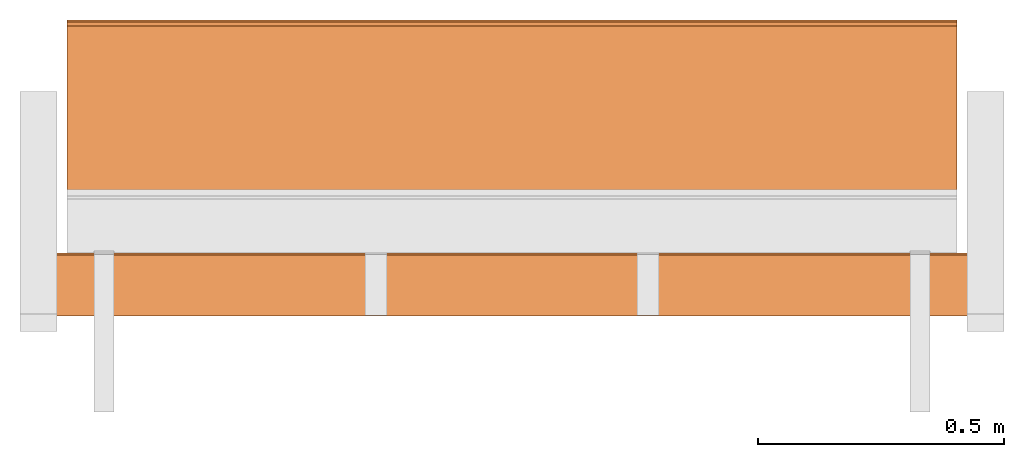
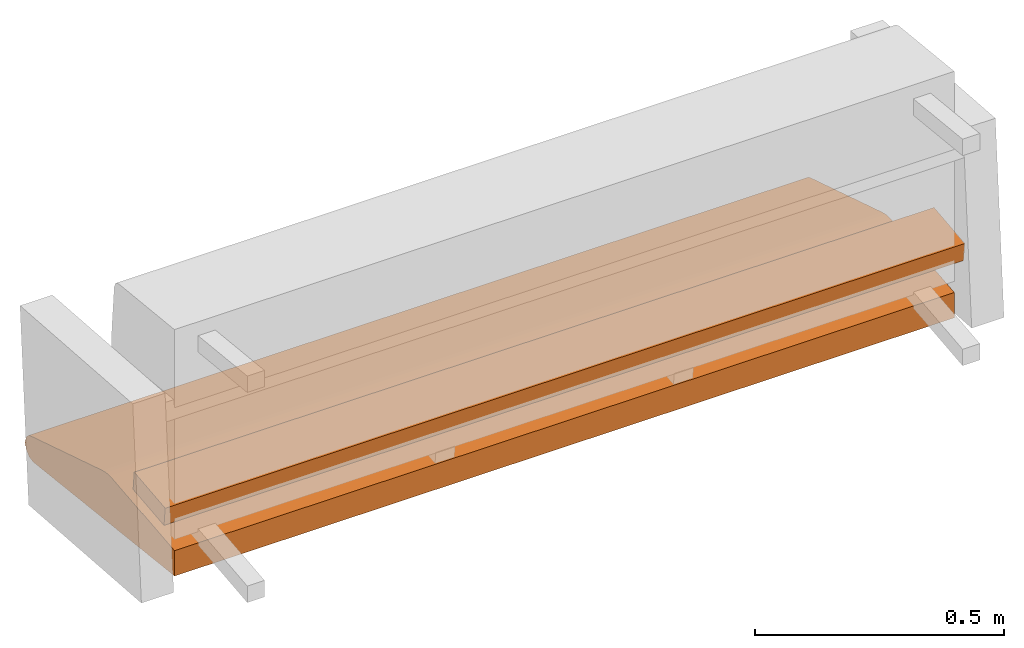
# One storey, part 2 of 4: 2 proxies, 1 element without a shape of its own.
"""IFC2X3 building model written with IfcOpenShell, lengths in metres."""

from ifc_helpers import new_model, si_unit, direction, origin_with_axes, place, context, project, spatial, faceted_brep, source, transform, mapped, element, aggregate, save


model = new_model("IFC2X3")

# Units and contexts
model_context = context("Model", 3, precision=1e-06, world=origin_with_axes(), true_north=direction((0.0, 1.0, 0.0)))
ifc_project = project(units=[si_unit("LENGTHUNIT", "METRE"), si_unit("AREAUNIT", "SQUARE_METRE"), si_unit("VOLUMEUNIT", "CUBIC_METRE")], contexts=[model_context])

# Site, building, storey
site_placement = place(None, origin_with_axes())
site = spatial("IfcSite", under=ifc_project, at=site_placement, CompositionType="ELEMENT")
building_placement = place(site_placement, origin_with_axes())
building = spatial("IfcBuilding", under=site, at=building_placement, Name="Default Building", CompositionType="ELEMENT")
storey_placement = place(building_placement, origin_with_axes())
storey = spatial("IfcBuildingStorey", under=building, at=storey_placement, Name="Default Storey", CompositionType="ELEMENT", Elevation=0.0)

# Assembly, proxies
assembly_placement = place(storey_placement, origin_with_axes())
assembly = element("IfcElementAssembly", 1, at=assembly_placement, inside=storey, Name="H-04-084-A_3-seater", ObjectType="H-04-084-A_3-seater", AssemblyPlace="NOTDEFINED", PredefinedType="NOTDEFINED")
shared_shape_1 = source(origin_with_axes(), model_context, "Body", "Brep", [
    faceted_brep([(-0.9049999713897705, 0.14882974326610565, -0.2589503824710846), (-0.9049999713897705, 0.1383768916130066, -0.2594982087612152), (0.9049999713897705, 0.14882974326610565, -0.2589503824710846), (0.9049999713897705, 0.14882974326610565, -0.2589503824710846), (-0.9049999713897705, 0.1383768916130066, -0.2594982087612152), (0.9049999713897705, 0.1383768916130066, -0.2594982087612152), (0.9049999713897705, 0.01817154325544834, -0.2721322774887085), (0.9049999713897705, 0.1383768916130066, -0.2594982087612152), (-0.9049999713897705, 0.01817154325544834, -0.2721322774887085), (-0.9049999713897705, 0.01817154325544834, -0.2721322774887085), (0.9049999713897705, 0.1383768916130066, -0.2594982087612152), (-0.9049999713897705, 0.1383768916130066, -0.2594982087612152), (0.9049999713897705, 0.17872387170791626, -0.2635232210159302), (-0.9049999713897705, 0.17872387170791626, -0.2635232210159302), (-0.9049999713897705, 0.16395066678524017, -0.26010021567344666), (0.9049999713897705, 0.17872387170791626, -0.2635232210159302), (-0.9049999713897705, 0.16395066678524017, -0.26010021567344666), (0.9049999713897705, 0.16395066678524017, -0.26010021567344666), (0.9049999713897705, 0.16395066678524017, -0.26010021567344666), (-0.9049999713897705, 0.16395066678524017, -0.26010021567344666), (-0.9049999713897705, 0.14882974326610565, -0.2589503824710846), (0.9049999713897705, 0.16395066678524017, -0.26010021567344666), (-0.9049999713897705, 0.14882974326610565, -0.2589503824710846), (0.9049999713897705, 0.14882974326610565, -0.2589503824710846), (0.9049999713897705, 0.17872387170791626, -0.2635232210159302), (0.9049999713897705, 0.4682733118534088, -0.3542293608188629), (-0.9049999713897705, 0.17872387170791626, -0.2635232210159302), (-0.9049999713897705, 0.17872387170791626, -0.2635232210159302), (0.9049999713897705, 0.4682733118534088, -0.3542293608188629), (-0.9049999713897705, 0.4682733118534088, -0.3542293608188629), (0.9049999713897705, 0.4682733118534088, -0.3542293608188629), (0.9049999713897705, 0.4762941300868988, -0.35816407203674316), (-0.9049999713897705, 0.4682733118534088, -0.3542293608188629), (-0.9049999713897705, 0.4682733118534088, -0.3542293608188629), (0.9049999713897705, 0.4762941300868988, -0.35816407203674316), (-0.9049999713897705, 0.4762941300868988, -0.35816407203674316), (0.9049999713897705, 0.4762941300868988, -0.35816407203674316), (0.9049999713897705, 0.4814260005950928, -0.36358925700187683), (-0.9049999713897705, 0.4762941300868988, -0.35816407203674316), (-0.9049999713897705, 0.4762941300868988, -0.35816407203674316), (0.9049999713897705, 0.4814260005950928, -0.36358925700187683), (-0.9049999713897705, 0.4814260005950928, -0.36358925700187683), (0.9049999713897705, 0.4814260005950928, -0.36358925700187683), (0.9049999713897705, 0.4845067262649536, -0.3668460547924042), (-0.9049999713897705, 0.4814260005950928, -0.36358925700187683), (-0.9049999713897705, 0.4814260005950928, -0.36358925700187683), (0.9049999713897705, 0.4845067262649536, -0.3668460547924042), (-0.9049999713897705, 0.4845067262649536, -0.3668460547924042), (0.9049999713897705, 0.4845067262649536, -0.3668460547924042), (0.9049999713897705, 0.48888999223709106, -0.3822925090789795), (-0.9049999713897705, 0.4845067262649536, -0.3668460547924042), (-0.9049999713897705, 0.4845067262649536, -0.3668460547924042), (0.9049999713897705, 0.48888999223709106, -0.3822925090789795), (-0.9049999713897705, 0.48888999223709106, -0.3822925090789795), (0.9049999713897705, 0.48888999223709106, -0.3822925090789795), (0.9049999713897705, 0.4845067262649536, -0.3977389633655548), (-0.9049999713897705, 0.48888999223709106, -0.3822925090789795), (-0.9049999713897705, 0.48888999223709106, -0.3822925090789795), (0.9049999713897705, 0.4845067262649536, -0.3977389633655548), (-0.9049999713897705, 0.4845067262649536, -0.3977389633655548), (0.9049999713897705, 0.4845067262649536, -0.3977389633655548), (0.9049999713897705, 0.4726635813713074, -0.40858080983161926), (-0.9049999713897705, 0.4845067262649536, -0.3977389633655548), (-0.9049999713897705, 0.4845067262649536, -0.3977389633655548), (0.9049999713897705, 0.4726635813713074, -0.40858080983161926), (-0.9049999713897705, 0.4726635813713074, -0.40858080983161926), (0.9049999713897705, 0.4726635813713074, -0.40858080983161926), (0.9049999713897705, 0.4568909704685211, -0.41158604621887207), (-0.9049999713897705, 0.4726635813713074, -0.40858080983161926), (-0.9049999713897705, 0.4726635813713074, -0.40858080983161926), (0.9049999713897705, 0.4568909704685211, -0.41158604621887207), (-0.9049999713897705, 0.4568909704685211, -0.41158604621887207), (0.9049999713897705, 0.4568909704685211, -0.41158604621887207), (0.9049999713897705, 0.4574563503265381, -0.4066162109375), (-0.9049999713897705, 0.4568909704685211, -0.41158604621887207), (-0.9049999713897705, 0.4568909704685211, -0.41158604621887207), (0.9049999713897705, 0.4574563503265381, -0.4066162109375), (-0.9049999713897705, 0.4574563503265381, -0.4066162109375), (0.9049999713897705, 0.4574563503265381, -0.4066162109375), (0.9049999713897705, 0.45688581466674805, -0.41162365674972534), (-0.9049999713897705, 0.4574563503265381, -0.4066162109375), (-0.9049999713897705, 0.4574563503265381, -0.4066162109375), (0.9049999713897705, 0.45688581466674805, -0.41162365674972534), (-0.9049999713897705, 0.45688581466674805, -0.41162365674972534), (0.9049999713897705, 0.45688581466674805, -0.41162365674972534), (0.9049999713897705, -0.11158759891986847, -0.3467162549495697), (-0.9049999713897705, 0.45688581466674805, -0.41162365674972534), (-0.9049999713897705, 0.45688581466674805, -0.41162365674972534), (0.9049999713897705, -0.11158759891986847, -0.3467162549495697), (-0.9049999713897705, -0.11158759891986847, -0.3467162549495697), (0.9049999713897705, -0.11158759891986847, -0.3467162549495697), (0.9049999713897705, -0.111614890396595, -0.34647175669670105), (-0.9049999713897705, -0.11158759891986847, -0.3467162549495697), (-0.9049999713897705, -0.11158759891986847, -0.3467162549495697), (0.9049999713897705, -0.111614890396595, -0.34647175669670105), (-0.9049999713897705, -0.111614890396595, -0.34647175669670105), (0.9049999713897705, -0.111614890396595, -0.34647175669670105), (0.9049999713897705, -0.11162230372428894, -0.3463222086429596), (-0.9049999713897705, -0.111614890396595, -0.34647175669670105), (-0.9049999713897705, -0.111614890396595, -0.34647175669670105), (0.9049999713897705, -0.11162230372428894, -0.3463222086429596), (-0.9049999713897705, -0.11162230372428894, -0.3463222086429596), (0.9049999713897705, -0.11162230372428894, -0.3463222086429596), (0.9049999713897705, -0.11162848770618439, -0.3461674153804779), (-0.9049999713897705, -0.11162230372428894, -0.3463222086429596), (-0.9049999713897705, -0.11162230372428894, -0.3463222086429596), (0.9049999713897705, -0.11162848770618439, -0.3461674153804779), (-0.9049999713897705, -0.11162848770618439, -0.3461674153804779), (0.9049999713897705, -0.11162848770618439, -0.3461674153804779), (0.9049999713897705, -0.11163215339183807, -0.3459841310977936), (-0.9049999713897705, -0.11162848770618439, -0.3461674153804779), (-0.9049999713897705, -0.11162848770618439, -0.3461674153804779), (0.9049999713897705, -0.11163215339183807, -0.3459841310977936), (-0.9049999713897705, -0.11163215339183807, -0.3459841310977936), (0.9049999713897705, -0.11163215339183807, -0.3459841310977936), (0.9049999713897705, -0.11163294315338135, -0.3458006978034973), (-0.9049999713897705, -0.11163215339183807, -0.3459841310977936), (-0.9049999713897705, -0.11163215339183807, -0.3459841310977936), (0.9049999713897705, -0.11163294315338135, -0.3458006978034973), (-0.9049999713897705, -0.11163294315338135, -0.3458006978034973), (0.9049999713897705, -0.11163294315338135, -0.3458006978034973), (0.9049999713897705, -0.11163128912448883, -0.34556692838668823), (-0.9049999713897705, -0.11163294315338135, -0.3458006978034973), (-0.9049999713897705, -0.11163294315338135, -0.3458006978034973), (0.9049999713897705, -0.11163128912448883, -0.34556692838668823), (-0.9049999713897705, -0.11163128912448883, -0.34556692838668823), (0.9049999713897705, -0.11163128912448883, -0.34556692838668823), (0.9049999713897705, -0.11162881553173065, -0.3453170657157898), (-0.9049999713897705, -0.11163128912448883, -0.34556692838668823), (-0.9049999713897705, -0.11163128912448883, -0.34556692838668823), (0.9049999713897705, -0.11162881553173065, -0.3453170657157898), (-0.9049999713897705, -0.11162881553173065, -0.3453170657157898), (0.9049999713897705, -0.11162881553173065, -0.3453170657157898), (0.9049999713897705, -0.11162382364273071, -0.34508395195007324), (-0.9049999713897705, -0.11162881553173065, -0.3453170657157898), (-0.9049999713897705, -0.11162881553173065, -0.3453170657157898), (0.9049999713897705, -0.11162382364273071, -0.34508395195007324), (-0.9049999713897705, -0.11162382364273071, -0.34508395195007324), (0.9049999713897705, -0.11162382364273071, -0.34508395195007324), (0.9049999713897705, -0.11161737889051437, -0.34479713439941406), (-0.9049999713897705, -0.11162382364273071, -0.34508395195007324), (-0.9049999713897705, -0.11162382364273071, -0.34508395195007324), (0.9049999713897705, -0.11161737889051437, -0.34479713439941406), (-0.9049999713897705, -0.11161737889051437, -0.34479713439941406), (0.9049999713897705, -0.11161737889051437, -0.34479713439941406), (0.9049999713897705, -0.11161097884178162, -0.3445703685283661), (-0.9049999713897705, -0.11161737889051437, -0.34479713439941406), (-0.9049999713897705, -0.11161737889051437, -0.34479713439941406), (0.9049999713897705, -0.11161097884178162, -0.3445703685283661), (-0.9049999713897705, -0.11161097884178162, -0.3445703685283661), (0.9049999713897705, -0.11161097884178162, -0.3445703685283661), (0.9049999713897705, -0.11160170286893845, -0.34428343176841736), (-0.9049999713897705, -0.11161097884178162, -0.3445703685283661), (-0.9049999713897705, -0.11161097884178162, -0.3445703685283661), (0.9049999713897705, -0.11160170286893845, -0.34428343176841736), (-0.9049999713897705, -0.11160170286893845, -0.34428343176841736), (0.9049999713897705, -0.11160170286893845, -0.34428343176841736), (0.9049999713897705, -0.11158967018127441, -0.3439476490020752), (-0.9049999713897705, -0.11160170286893845, -0.34428343176841736), (-0.9049999713897705, -0.11160170286893845, -0.34428343176841736), (0.9049999713897705, -0.11158967018127441, -0.3439476490020752), (-0.9049999713897705, -0.11158967018127441, -0.3439476490020752), (0.9049999713897705, -0.11158967018127441, -0.3439476490020752), (0.9049999713897705, -0.11157859116792679, -0.34364718198776245), (-0.9049999713897705, -0.11158967018127441, -0.3439476490020752), (-0.9049999713897705, -0.11158967018127441, -0.3439476490020752), (0.9049999713897705, -0.11157859116792679, -0.34364718198776245), (-0.9049999713897705, -0.11157859116792679, -0.34364718198776245), (0.9049999713897705, -0.11157859116792679, -0.34364718198776245), (0.9049999713897705, -0.1115475445985794, -0.3428836464881897), (-0.9049999713897705, -0.11157859116792679, -0.34364718198776245), (-0.9049999713897705, -0.11157859116792679, -0.34364718198776245), (0.9049999713897705, -0.1115475445985794, -0.3428836464881897), (-0.9049999713897705, -0.1115475445985794, -0.3428836464881897), (0.9049999713897705, -0.1115475445985794, -0.3428836464881897), (0.9049999713897705, -0.1115172728896141, -0.3421829342842102), (-0.9049999713897705, -0.1115475445985794, -0.3428836464881897), (-0.9049999713897705, -0.1115475445985794, -0.3428836464881897), (0.9049999713897705, -0.1115172728896141, -0.3421829342842102), (-0.9049999713897705, -0.1115172728896141, -0.3421829342842102), (0.9049999713897705, -0.1115172728896141, -0.3421829342842102), (0.9049999713897705, -0.11149738729000092, -0.34173157811164856), (-0.9049999713897705, -0.1115172728896141, -0.3421829342842102), (-0.9049999713897705, -0.1115172728896141, -0.3421829342842102), (0.9049999713897705, -0.11149738729000092, -0.34173157811164856), (-0.9049999713897705, -0.11149738729000092, -0.34173157811164856), (0.9049999713897705, -0.11149738729000092, -0.34173157811164856), (0.9049999713897705, -0.11122065782546997, -0.28472810983657837), (-0.9049999713897705, -0.11149738729000092, -0.34173157811164856), (-0.9049999713897705, -0.11149738729000092, -0.34173157811164856), (0.9049999713897705, -0.11122065782546997, -0.28472810983657837), (-0.9049999713897705, -0.11122065782546997, -0.28472810983657837), (0.9049999713897705, -0.11122065782546997, -0.28472810983657837), (0.9049999713897705, 0.01806718483567238, -0.27113938331604004), (-0.9049999713897705, -0.11122065782546997, -0.28472810983657837), (-0.9049999713897705, -0.11122065782546997, -0.28472810983657837), (0.9049999713897705, 0.01806718483567238, -0.27113938331604004), (-0.9049999713897705, 0.01806718483567238, -0.27113938331604004), (0.9049999713897705, 0.01806718483567238, -0.27113938331604004), (0.9049999713897705, 0.01817154325544834, -0.2721322774887085), (-0.9049999713897705, 0.01806718483567238, -0.27113938331604004), (-0.9049999713897705, 0.01806718483567238, -0.27113938331604004), (0.9049999713897705, 0.01817154325544834, -0.2721322774887085), (-0.9049999713897705, 0.01817154325544834, -0.2721322774887085), (0.9049999713897705, 0.4814260005950928, -0.36358925700187683), (0.9049999713897705, 0.4762941300868988, -0.35816407203674316), (0.9049999713897705, 0.4682733118534088, -0.3542293608188629), (0.9049999713897705, 0.4574563503265381, -0.4066162109375), (0.9049999713897705, 0.4568909704685211, -0.41158604621887207), (0.9049999713897705, 0.4726635813713074, -0.40858080983161926), (0.9049999713897705, -0.11158759891986847, -0.3467162549495697), (0.9049999713897705, 0.45688581466674805, -0.41162365674972534), (0.9049999713897705, 0.4574563503265381, -0.4066162109375), (0.9049999713897705, 0.4845067262649536, -0.3668460547924042), (0.9049999713897705, 0.4814260005950928, -0.36358925700187683), (0.9049999713897705, 0.4574563503265381, -0.4066162109375), (0.9049999713897705, 0.01806718483567238, -0.27113938331604004), (0.9049999713897705, -0.11122065782546997, -0.28472810983657837), (0.9049999713897705, 0.01817154325544834, -0.2721322774887085), (0.9049999713897705, 0.01817154325544834, -0.2721322774887085), (0.9049999713897705, -0.11122065782546997, -0.28472810983657837), (0.9049999713897705, -0.11149738729000092, -0.34173157811164856), (0.9049999713897705, 0.16395066678524017, -0.26010021567344666), (0.9049999713897705, 0.14882974326610565, -0.2589503824710846), (0.9049999713897705, 0.4574563503265381, -0.4066162109375), (0.9049999713897705, 0.4574563503265381, -0.4066162109375), (0.9049999713897705, 0.14882974326610565, -0.2589503824710846), (0.9049999713897705, 0.1383768916130066, -0.2594982087612152), (0.9049999713897705, 0.4574563503265381, -0.4066162109375), (0.9049999713897705, 0.1383768916130066, -0.2594982087612152), (0.9049999713897705, -0.11158759891986847, -0.3467162549495697), (0.9049999713897705, -0.11158759891986847, -0.3467162549495697), (0.9049999713897705, 0.1383768916130066, -0.2594982087612152), (0.9049999713897705, 0.01817154325544834, -0.2721322774887085), (0.9049999713897705, -0.11158759891986847, -0.3467162549495697), (0.9049999713897705, 0.01817154325544834, -0.2721322774887085), (0.9049999713897705, -0.111614890396595, -0.34647175669670105), (0.9049999713897705, 0.4726635813713074, -0.40858080983161926), (0.9049999713897705, 0.4845067262649536, -0.3977389633655548), (0.9049999713897705, 0.4574563503265381, -0.4066162109375), (0.9049999713897705, 0.4574563503265381, -0.4066162109375), (0.9049999713897705, 0.4845067262649536, -0.3977389633655548), (0.9049999713897705, 0.48888999223709106, -0.3822925090789795), (0.9049999713897705, 0.4574563503265381, -0.4066162109375), (0.9049999713897705, 0.48888999223709106, -0.3822925090789795), (0.9049999713897705, 0.4845067262649536, -0.3668460547924042), (0.9049999713897705, 0.4814260005950928, -0.36358925700187683), (0.9049999713897705, 0.4682733118534088, -0.3542293608188629), (0.9049999713897705, 0.4574563503265381, -0.4066162109375), (0.9049999713897705, 0.4574563503265381, -0.4066162109375), (0.9049999713897705, 0.4682733118534088, -0.3542293608188629), (0.9049999713897705, 0.17872387170791626, -0.2635232210159302), (0.9049999713897705, 0.4574563503265381, -0.4066162109375), (0.9049999713897705, 0.17872387170791626, -0.2635232210159302), (0.9049999713897705, 0.16395066678524017, -0.26010021567344666), (0.9049999713897705, -0.11149738729000092, -0.34173157811164856), (0.9049999713897705, -0.1115172728896141, -0.3421829342842102), (0.9049999713897705, 0.01817154325544834, -0.2721322774887085), (0.9049999713897705, 0.01817154325544834, -0.2721322774887085), (0.9049999713897705, -0.1115172728896141, -0.3421829342842102), (0.9049999713897705, -0.1115475445985794, -0.3428836464881897), (0.9049999713897705, 0.01817154325544834, -0.2721322774887085), (0.9049999713897705, -0.1115475445985794, -0.3428836464881897), (0.9049999713897705, -0.11157859116792679, -0.34364718198776245), (0.9049999713897705, -0.11157859116792679, -0.34364718198776245), (0.9049999713897705, -0.11158967018127441, -0.3439476490020752), (0.9049999713897705, 0.01817154325544834, -0.2721322774887085), (0.9049999713897705, 0.01817154325544834, -0.2721322774887085), (0.9049999713897705, -0.11158967018127441, -0.3439476490020752), (0.9049999713897705, -0.11160170286893845, -0.34428343176841736), (0.9049999713897705, 0.01817154325544834, -0.2721322774887085), (0.9049999713897705, -0.11160170286893845, -0.34428343176841736), (0.9049999713897705, -0.11161097884178162, -0.3445703685283661), (0.9049999713897705, -0.11161097884178162, -0.3445703685283661), (0.9049999713897705, -0.11161737889051437, -0.34479713439941406), (0.9049999713897705, 0.01817154325544834, -0.2721322774887085), (0.9049999713897705, 0.01817154325544834, -0.2721322774887085), (0.9049999713897705, -0.11161737889051437, -0.34479713439941406), (0.9049999713897705, -0.11162382364273071, -0.34508395195007324), (0.9049999713897705, 0.01817154325544834, -0.2721322774887085), (0.9049999713897705, -0.11162382364273071, -0.34508395195007324), (0.9049999713897705, -0.11162881553173065, -0.3453170657157898), (0.9049999713897705, -0.11162881553173065, -0.3453170657157898), (0.9049999713897705, -0.11163128912448883, -0.34556692838668823), (0.9049999713897705, 0.01817154325544834, -0.2721322774887085), (0.9049999713897705, 0.01817154325544834, -0.2721322774887085), (0.9049999713897705, -0.11163128912448883, -0.34556692838668823), (0.9049999713897705, -0.11163294315338135, -0.3458006978034973), (0.9049999713897705, 0.01817154325544834, -0.2721322774887085), (0.9049999713897705, -0.11163294315338135, -0.3458006978034973), (0.9049999713897705, -0.11163215339183807, -0.3459841310977936), (0.9049999713897705, -0.11163215339183807, -0.3459841310977936), (0.9049999713897705, -0.11162848770618439, -0.3461674153804779), (0.9049999713897705, 0.01817154325544834, -0.2721322774887085), (0.9049999713897705, 0.01817154325544834, -0.2721322774887085), (0.9049999713897705, -0.11162848770618439, -0.3461674153804779), (0.9049999713897705, -0.11162230372428894, -0.3463222086429596), (0.9049999713897705, 0.01817154325544834, -0.2721322774887085), (0.9049999713897705, -0.11162230372428894, -0.3463222086429596), (0.9049999713897705, -0.111614890396595, -0.34647175669670105), (-0.9049999713897705, 0.4574563503265381, -0.4066162109375), (-0.9049999713897705, 0.45688581466674805, -0.41162365674972534), (-0.9049999713897705, -0.11158759891986847, -0.3467162549495697), (-0.9049999713897705, 0.4682733118534088, -0.3542293608188629), (-0.9049999713897705, 0.4762941300868988, -0.35816407203674316), (-0.9049999713897705, 0.4574563503265381, -0.4066162109375), (-0.9049999713897705, 0.4574563503265381, -0.4066162109375), (-0.9049999713897705, 0.4762941300868988, -0.35816407203674316), (-0.9049999713897705, 0.4814260005950928, -0.36358925700187683), (-0.9049999713897705, 0.4726635813713074, -0.40858080983161926), (-0.9049999713897705, 0.4568909704685211, -0.41158604621887207), (-0.9049999713897705, 0.4574563503265381, -0.4066162109375), (-0.9049999713897705, -0.11122065782546997, -0.28472810983657837), (-0.9049999713897705, 0.01806718483567238, -0.27113938331604004), (-0.9049999713897705, -0.11149738729000092, -0.34173157811164856), (-0.9049999713897705, -0.11149738729000092, -0.34173157811164856), (-0.9049999713897705, 0.01806718483567238, -0.27113938331604004), (-0.9049999713897705, 0.01817154325544834, -0.2721322774887085), (-0.9049999713897705, -0.11149738729000092, -0.34173157811164856), (-0.9049999713897705, 0.01817154325544834, -0.2721322774887085), (-0.9049999713897705, -0.1115172728896141, -0.3421829342842102), (-0.9049999713897705, -0.11160170286893845, -0.34428343176841736), (-0.9049999713897705, -0.11158967018127441, -0.3439476490020752), (-0.9049999713897705, 0.01817154325544834, -0.2721322774887085), (-0.9049999713897705, 0.4845067262649536, -0.3977389633655548), (-0.9049999713897705, 0.4726635813713074, -0.40858080983161926), (-0.9049999713897705, 0.48888999223709106, -0.3822925090789795), (-0.9049999713897705, 0.48888999223709106, -0.3822925090789795), (-0.9049999713897705, 0.4726635813713074, -0.40858080983161926), (-0.9049999713897705, 0.4574563503265381, -0.4066162109375), (-0.9049999713897705, 0.48888999223709106, -0.3822925090789795), (-0.9049999713897705, 0.4574563503265381, -0.4066162109375), (-0.9049999713897705, 0.4845067262649536, -0.3668460547924042), (-0.9049999713897705, 0.4845067262649536, -0.3668460547924042), (-0.9049999713897705, 0.4574563503265381, -0.4066162109375), (-0.9049999713897705, 0.4814260005950928, -0.36358925700187683), (-0.9049999713897705, 0.01817154325544834, -0.2721322774887085), (-0.9049999713897705, 0.1383768916130066, -0.2594982087612152), (-0.9049999713897705, 0.4574563503265381, -0.4066162109375), (-0.9049999713897705, 0.4574563503265381, -0.4066162109375), (-0.9049999713897705, 0.1383768916130066, -0.2594982087612152), (-0.9049999713897705, 0.14882974326610565, -0.2589503824710846), (-0.9049999713897705, -0.11158967018127441, -0.3439476490020752), (-0.9049999713897705, -0.11157859116792679, -0.34364718198776245), (-0.9049999713897705, 0.01817154325544834, -0.2721322774887085), (-0.9049999713897705, 0.01817154325544834, -0.2721322774887085), (-0.9049999713897705, -0.11157859116792679, -0.34364718198776245), (-0.9049999713897705, -0.1115475445985794, -0.3428836464881897), (-0.9049999713897705, 0.01817154325544834, -0.2721322774887085), (-0.9049999713897705, -0.1115475445985794, -0.3428836464881897), (-0.9049999713897705, -0.1115172728896141, -0.3421829342842102), (-0.9049999713897705, 0.14882974326610565, -0.2589503824710846), (-0.9049999713897705, 0.16395066678524017, -0.26010021567344666), (-0.9049999713897705, 0.4574563503265381, -0.4066162109375), (-0.9049999713897705, 0.4574563503265381, -0.4066162109375), (-0.9049999713897705, 0.16395066678524017, -0.26010021567344666), (-0.9049999713897705, 0.17872387170791626, -0.2635232210159302), (-0.9049999713897705, 0.4574563503265381, -0.4066162109375), (-0.9049999713897705, 0.17872387170791626, -0.2635232210159302), (-0.9049999713897705, 0.4682733118534088, -0.3542293608188629), (-0.9049999713897705, -0.11163294315338135, -0.3458006978034973), (-0.9049999713897705, -0.11163128912448883, -0.34556692838668823), (-0.9049999713897705, 0.01817154325544834, -0.2721322774887085), (-0.9049999713897705, 0.01817154325544834, -0.2721322774887085), (-0.9049999713897705, -0.11163128912448883, -0.34556692838668823), (-0.9049999713897705, -0.11162881553173065, -0.3453170657157898), (-0.9049999713897705, 0.01817154325544834, -0.2721322774887085), (-0.9049999713897705, -0.11162881553173065, -0.3453170657157898), (-0.9049999713897705, -0.11162382364273071, -0.34508395195007324), (-0.9049999713897705, 0.4574563503265381, -0.4066162109375), (-0.9049999713897705, -0.11158759891986847, -0.3467162549495697), (-0.9049999713897705, 0.01817154325544834, -0.2721322774887085), (-0.9049999713897705, 0.01817154325544834, -0.2721322774887085), (-0.9049999713897705, -0.11158759891986847, -0.3467162549495697), (-0.9049999713897705, -0.111614890396595, -0.34647175669670105), (-0.9049999713897705, 0.01817154325544834, -0.2721322774887085), (-0.9049999713897705, -0.111614890396595, -0.34647175669670105), (-0.9049999713897705, -0.11162230372428894, -0.3463222086429596), (-0.9049999713897705, -0.11162382364273071, -0.34508395195007324), (-0.9049999713897705, -0.11161737889051437, -0.34479713439941406), (-0.9049999713897705, 0.01817154325544834, -0.2721322774887085), (-0.9049999713897705, 0.01817154325544834, -0.2721322774887085), (-0.9049999713897705, -0.11161737889051437, -0.34479713439941406), (-0.9049999713897705, -0.11161097884178162, -0.3445703685283661), (-0.9049999713897705, 0.01817154325544834, -0.2721322774887085), (-0.9049999713897705, -0.11161097884178162, -0.3445703685283661), (-0.9049999713897705, -0.11160170286893845, -0.34428343176841736), (-0.9049999713897705, -0.11162230372428894, -0.3463222086429596), (-0.9049999713897705, -0.11162848770618439, -0.3461674153804779), (-0.9049999713897705, 0.01817154325544834, -0.2721322774887085), (-0.9049999713897705, 0.01817154325544834, -0.2721322774887085), (-0.9049999713897705, -0.11162848770618439, -0.3461674153804779), (-0.9049999713897705, -0.11163215339183807, -0.3459841310977936), (-0.9049999713897705, 0.01817154325544834, -0.2721322774887085), (-0.9049999713897705, -0.11163215339183807, -0.3459841310977936), (-0.9049999713897705, -0.11163294315338135, -0.3458006978034973)], [[[0, 1, 2]], [[3, 4, 5]], [[6, 7, 8]], [[9, 10, 11]], [[12, 13, 14]], [[15, 16, 17]], [[18, 19, 20]], [[21, 22, 23]], [[24, 25, 26]], [[27, 28, 29]], [[30, 31, 32]], [[33, 34, 35]], [[36, 37, 38]], [[39, 40, 41]], [[42, 43, 44]], [[45, 46, 47]], [[48, 49, 50]], [[51, 52, 53]], [[54, 55, 56]], [[57, 58, 59]], [[60, 61, 62]], [[63, 64, 65]], [[66, 67, 68]], [[69, 70, 71]], [[72, 73, 74]], [[75, 76, 77]], [[78, 79, 80]], [[81, 82, 83]], [[84, 85, 86]], [[87, 88, 89]], [[90, 91, 92]], [[93, 94, 95]], [[96, 97, 98]], [[99, 100, 101]], [[102, 103, 104]], [[105, 106, 107]], [[108, 109, 110]], [[111, 112, 113]], [[114, 115, 116]], [[117, 118, 119]], [[120, 121, 122]], [[123, 124, 125]], [[126, 127, 128]], [[129, 130, 131]], [[132, 133, 134]], [[135, 136, 137]], [[138, 139, 140]], [[141, 142, 143]], [[144, 145, 146]], [[147, 148, 149]], [[150, 151, 152]], [[153, 154, 155]], [[156, 157, 158]], [[159, 160, 161]], [[162, 163, 164]], [[165, 166, 167]], [[168, 169, 170]], [[171, 172, 173]], [[174, 175, 176]], [[177, 178, 179]], [[180, 181, 182]], [[183, 184, 185]], [[186, 187, 188]], [[189, 190, 191]], [[192, 193, 194]], [[195, 196, 197]], [[198, 199, 200]], [[201, 202, 203]], [[204, 205, 206]], [[207, 208, 209]], [[210, 211, 212]], [[213, 214, 215]], [[216, 217, 218]], [[219, 220, 221]], [[222, 223, 224]], [[225, 226, 227]], [[228, 229, 230]], [[231, 232, 233]], [[234, 235, 236]], [[237, 238, 239]], [[240, 241, 242]], [[243, 244, 245]], [[246, 247, 248]], [[249, 250, 251]], [[252, 253, 254]], [[255, 256, 257]], [[258, 259, 260]], [[261, 262, 263]], [[264, 265, 266]], [[267, 268, 269]], [[270, 271, 272]], [[273, 274, 275]], [[276, 277, 278]], [[279, 280, 281]], [[282, 283, 284]], [[285, 286, 287]], [[288, 289, 290]], [[291, 292, 293]], [[294, 295, 296]], [[297, 298, 299]], [[300, 301, 302]], [[303, 304, 305]], [[306, 307, 308]], [[309, 310, 311]], [[312, 313, 314]], [[315, 316, 317]], [[318, 319, 320]], [[321, 322, 323]], [[324, 325, 326]], [[327, 328, 329]], [[330, 331, 332]], [[333, 334, 335]], [[336, 337, 338]], [[339, 340, 341]], [[342, 343, 344]], [[345, 346, 347]], [[348, 349, 350]], [[351, 352, 353]], [[354, 355, 356]], [[357, 358, 359]], [[360, 361, 362]], [[363, 364, 365]], [[366, 367, 368]], [[369, 370, 371]], [[372, 373, 374]], [[375, 376, 377]], [[378, 379, 380]], [[381, 382, 383]], [[384, 385, 386]], [[387, 388, 389]], [[390, 391, 392]], [[393, 394, 395]]]),
])
proxy_1_placement = place(assembly_placement, origin_with_axes())
proxy_1 = element("IfcBuildingElementProxy", 2, at=proxy_1_placement, Name="6", ObjectType="6", CompositionType="ELEMENT", context=model_context, shape_type="MappedRepresentation", body=[
    mapped(shared_shape_1, transform((0.0, 0.0, 0.0), scale=1.0)),
])
shared_shape_2 = source(origin_with_axes(), model_context, "Body", "Brep", [
    faceted_brep([(0.9280000329017639, -0.11368481069803238, -0.17104563117027283), (0.9280000329017639, 0.010630584321916103, -0.1579795628786087), (-0.9279999732971191, -0.11368496716022491, -0.17104412615299225), (-0.9279999732971191, -0.11368496716022491, -0.17104412615299225), (0.9280000329017639, 0.010630584321916103, -0.1579795628786087), (-0.9279999732971191, 0.010630425997078419, -0.15797805786132812), (0.9279999732971191, -0.10898102819919586, -0.21579913794994354), (0.9280000329017639, -0.11368481069803238, -0.17104563117027283), (-0.9280000329017639, -0.1089811846613884, -0.21579763293266296), (-0.9280000329017639, -0.1089811846613884, -0.21579763293266296), (0.9280000329017639, -0.11368481069803238, -0.17104563117027283), (-0.9279999732971191, -0.11368496716022491, -0.17104412615299225), (0.9279999732971191, 0.015334367752075195, -0.20273306965827942), (0.9279999732971191, -0.10898102819919586, -0.21579913794994354), (-0.9280000329017639, 0.01533420942723751, -0.20273156464099884), (-0.9280000329017639, 0.01533420942723751, -0.20273156464099884), (0.9279999732971191, -0.10898102819919586, -0.21579913794994354), (-0.9280000329017639, -0.1089811846613884, -0.21579763293266296), (0.9280000329017639, 0.010630584321916103, -0.1579795628786087), (0.9279999732971191, 0.015334367752075195, -0.20273306965827942), (-0.9279999732971191, 0.010630425997078419, -0.15797805786132812), (-0.9279999732971191, 0.010630425997078419, -0.15797805786132812), (0.9279999732971191, 0.015334367752075195, -0.20273306965827942), (-0.9280000329017639, 0.01533420942723751, -0.20273156464099884), (0.9279999732971191, -0.10898102819919586, -0.21579913794994354), (0.9279999732971191, 0.015334367752075195, -0.20273306965827942), (0.9280000329017639, -0.11368481069803238, -0.17104563117027283), (0.9280000329017639, -0.11368481069803238, -0.17104563117027283), (0.9279999732971191, 0.015334367752075195, -0.20273306965827942), (0.9280000329017639, 0.010630584321916103, -0.1579795628786087), (-0.9280000329017639, 0.01533420942723751, -0.20273156464099884), (-0.9280000329017639, -0.1089811846613884, -0.21579763293266296), (-0.9279999732971191, 0.010630425997078419, -0.15797805786132812), (-0.9279999732971191, 0.010630425997078419, -0.15797805786132812), (-0.9280000329017639, -0.1089811846613884, -0.21579763293266296), (-0.9279999732971191, -0.11368496716022491, -0.17104412615299225)], [[[0, 1, 2]], [[3, 4, 5]], [[6, 7, 8]], [[9, 10, 11]], [[12, 13, 14]], [[15, 16, 17]], [[18, 19, 20]], [[21, 22, 23]], [[24, 25, 26]], [[27, 28, 29]], [[30, 31, 32]], [[33, 34, 35]]]),
])
proxy_2_placement = place(assembly_placement, origin_with_axes())
proxy_2 = element("IfcBuildingElementProxy", 3, at=proxy_2_placement, Name="10", ObjectType="10", CompositionType="ELEMENT", context=model_context, shape_type="MappedRepresentation", body=[
    mapped(shared_shape_2, transform((0.0, 0.0, 0.0), scale=1.0)),
])
aggregate(assembly, [proxy_1, proxy_2])

save(model, "model.ifc")
